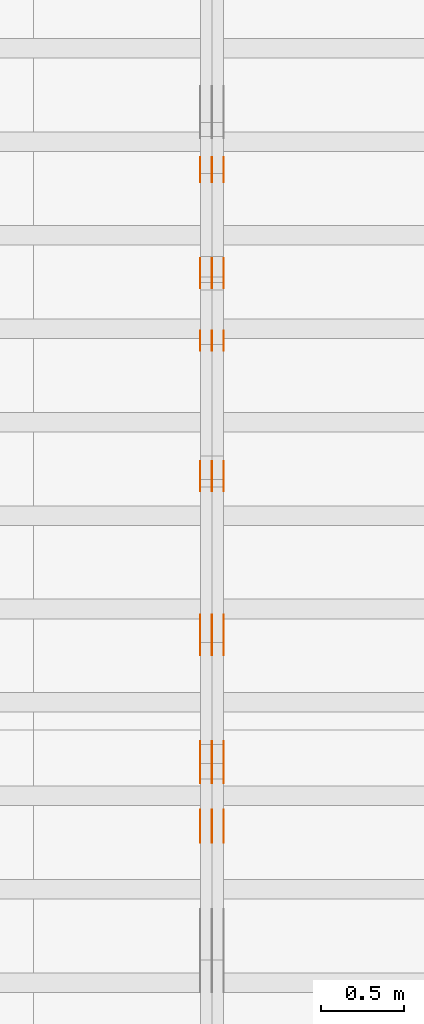
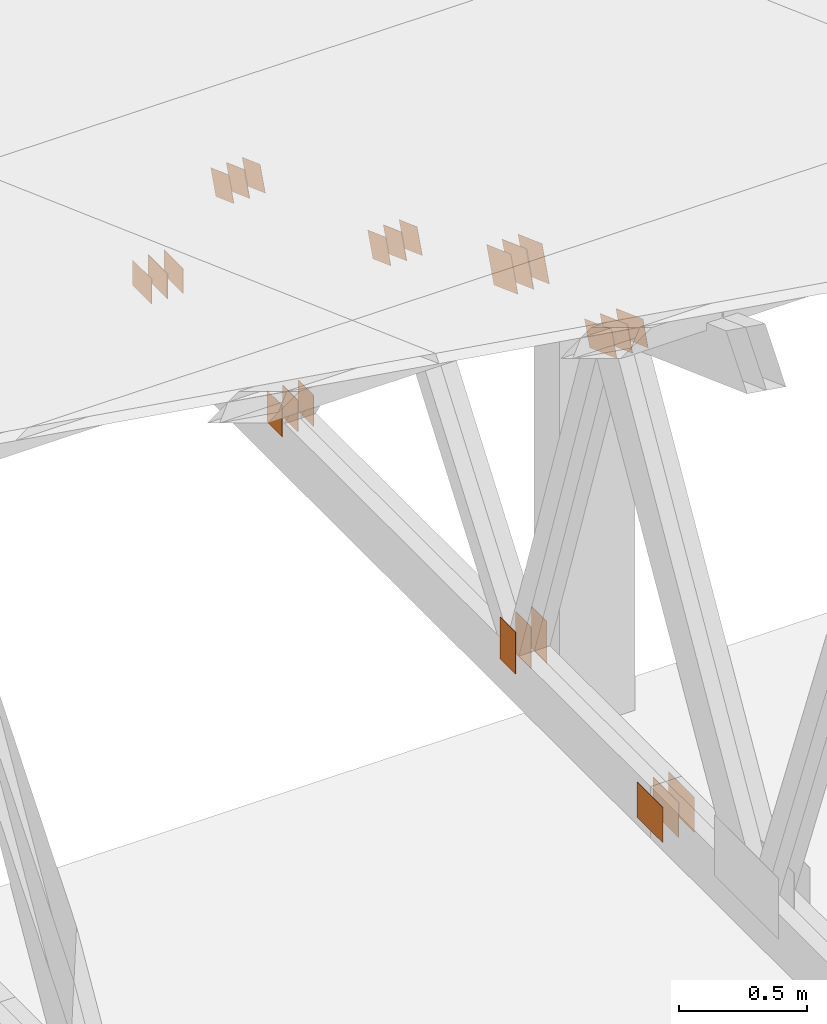
# One storey, part 128 of 189: 32 proxies.
"""IFC2X3 building model written with IfcOpenShell, lengths in millimetres."""

from ifc_helpers import new_model, entity, si_unit, converted_unit, derived_unit, direction, frame, frame_2d, origin, origin_2d_with_axis, place, context, subcontext, project, spatial, polyline, rectangle, outline, extrude, source, transform, mapped, material, type_object, type_shapes, element, save


model = new_model("IFC2X3")

# Units and contexts
model_context = context("Model", 3, precision=0.01, world=origin(), true_north=direction((6.12303176911189e-17, 1.0)))
body_context = subcontext(model_context, "Body", "Model", "MODEL_VIEW")
ifc_project = project(units=[si_unit("LENGTHUNIT", "METRE", prefix="MILLI"), si_unit("AREAUNIT", "SQUARE_METRE"), si_unit("VOLUMEUNIT", "CUBIC_METRE"), converted_unit("PLANEANGLEUNIT", "DEGREE", entity("IfcRatioMeasure", 0.0174532925199433), si_unit("PLANEANGLEUNIT", "RADIAN"), dimensions=[0, 0, 0, 0, 0, 0, 0]), si_unit("MASSUNIT", "GRAM", prefix="KILO"), derived_unit("MASSDENSITYUNIT", [(si_unit("MASSUNIT", "GRAM", prefix="KILO"), 1), (si_unit("LENGTHUNIT", "METRE"), -3)]), si_unit("TIMEUNIT", "SECOND"), si_unit("FREQUENCYUNIT", "HERTZ"), si_unit("THERMODYNAMICTEMPERATUREUNIT", "DEGREE_CELSIUS"), derived_unit("THERMALTRANSMITTANCEUNIT", [(si_unit("MASSUNIT", "GRAM", prefix="KILO"), 1), (si_unit("THERMODYNAMICTEMPERATUREUNIT", "KELVIN"), -1), (si_unit("TIMEUNIT", "SECOND"), -3)]), derived_unit("VOLUMETRICFLOWRATEUNIT", [(si_unit("LENGTHUNIT", "METRE"), 3), (si_unit("TIMEUNIT", "SECOND"), -1)]), si_unit("ELECTRICCURRENTUNIT", "AMPERE"), si_unit("ELECTRICVOLTAGEUNIT", "VOLT"), si_unit("POWERUNIT", "WATT"), si_unit("FORCEUNIT", "NEWTON"), si_unit("ILLUMINANCEUNIT", "LUX"), si_unit("LUMINOUSFLUXUNIT", "LUMEN"), si_unit("LUMINOUSINTENSITYUNIT", "CANDELA"), derived_unit("USERDEFINED", [(si_unit("MASSUNIT", "GRAM", prefix="KILO"), -1), (si_unit("LENGTHUNIT", "METRE"), -2), (si_unit("TIMEUNIT", "SECOND"), 3), (si_unit("LUMINOUSFLUXUNIT", "LUMEN"), 1)]), derived_unit("LINEARVELOCITYUNIT", [(si_unit("LENGTHUNIT", "METRE"), 1), (si_unit("TIMEUNIT", "SECOND"), -1)]), si_unit("PRESSUREUNIT", "PASCAL"), derived_unit("USERDEFINED", [(si_unit("LENGTHUNIT", "METRE"), -2), (si_unit("MASSUNIT", "GRAM", prefix="KILO"), 1), (si_unit("TIMEUNIT", "SECOND"), -2)])], contexts=[model_context])

# Site, building, storey
site_placement = place(None, origin())
site = spatial("IfcSite", under=ifc_project, at=site_placement, CompositionType="ELEMENT")
building_placement = place(site_placement, origin())
building = spatial("IfcBuilding", under=site, at=building_placement, CompositionType="ELEMENT")
storey_placement = place(building_placement, origin())
storey = spatial("IfcBuildingStorey", under=building, at=storey_placement, Name="Default", CompositionType="ELEMENT", Elevation=0.0)

# Proxies
ifc_material_1 = material(Name="IfcSurfaceStyle #122268")
building_element_proxy_type_1 = type_object("IfcBuildingElementProxyType", PredefinedType="NOTDEFINED", material=ifc_material_1)
shared_shape_1 = source(origin(), body_context, "Body", "SweptSolid", [
    extrude(outline(polyline([(-112.499846801582, -59.999986193028), (112.499924372729, -59.999986193028), (112.499888552087, 59.999986193028), (-112.499966123235, 59.999986193028), (-112.499846801582, -59.999986193028)])), frame((112.499989807712, 60.0001003787081, 0.0), z_axis=(0.0, 0.0, 1.0), x_axis=(-1.0, 0.0, 0.0)), (0.0, 0.0, 1.0), 1.3),
])
type_shapes(building_element_proxy_type_1, [shared_shape_1])
proxy_1_placement = place(building_placement, frame((21301.3, 24040.8868138992, 2049.61031693104), z_axis=(-1.0, 0.0, 0.0), x_axis=(0.0, -0.939692620785908, 0.342020143325669)))
element("IfcBuildingElementProxy", 1, at=proxy_1_placement, inside=storey, type_object=building_element_proxy_type_1, material=ifc_material_1, context=body_context, shape_type="MappedRepresentation", body=[
    mapped(shared_shape_1, transform((0.0, 0.0, 0.0), scale=1.0)),
])
ifc_material_2 = material(Name="IfcSurfaceStyle #122211")
building_element_proxy_type_2 = type_object("IfcBuildingElementProxyType", PredefinedType="NOTDEFINED", material=ifc_material_2)
shared_shape_2 = source(origin(), body_context, "Body", "SweptSolid", [
    extrude(outline(polyline([(-112.499846801582, -59.999986193028), (112.499924372729, -59.999986193028), (112.499888552087, 59.999986193028), (-112.499966123235, 59.999986193028), (-112.499846801582, -59.999986193028)])), frame((112.499989807712, 60.0001003787081, 0.0), z_axis=(0.0, 0.0, 1.0), x_axis=(-1.0, 0.0, 0.0)), (0.0, 0.0, 1.0), 1.29999999999998),
])
type_shapes(building_element_proxy_type_2, [shared_shape_2])
proxy_2_placement = place(building_placement, frame((21230.0, 24040.8868138992, 2049.61031693104), z_axis=(-1.0, 0.0, 0.0), x_axis=(0.0, -0.939692620785908, 0.342020143325669)))
element("IfcBuildingElementProxy", 2, at=proxy_2_placement, inside=storey, type_object=building_element_proxy_type_2, material=ifc_material_2, context=body_context, shape_type="MappedRepresentation", body=[
    mapped(shared_shape_2, transform((0.0, 0.0, 0.0), scale=1.0)),
])
ifc_material_3 = material(Name="IfcSurfaceStyle #122154")
building_element_proxy_type_3 = type_object("IfcBuildingElementProxyType", PredefinedType="NOTDEFINED", material=ifc_material_3)
shared_shape_3 = source(origin(), body_context, "Body", "SweptSolid", [
    extrude(outline(polyline([(-112.499846801582, -59.999986193028), (112.499924372729, -59.999986193028), (112.499888552087, 59.999986193028), (-112.499966123235, 59.999986193028), (-112.499846801582, -59.999986193028)])), frame((112.499989807712, 60.0001003787081, 0.0), z_axis=(0.0, 0.0, 1.0), x_axis=(-1.0, 0.0, 0.0)), (0.0, 0.0, 1.0), 1.29999999999998),
])
type_shapes(building_element_proxy_type_3, [shared_shape_3])
proxy_3_placement = place(building_placement, frame((21231.3, 24040.8868138992, 2049.61031693104), z_axis=(-1.0, 0.0, 0.0), x_axis=(0.0, -0.939692620785908, 0.342020143325669)))
element("IfcBuildingElementProxy", 3, at=proxy_3_placement, inside=storey, type_object=building_element_proxy_type_3, material=ifc_material_3, context=body_context, shape_type="MappedRepresentation", body=[
    mapped(shared_shape_3, transform((0.0, 0.0, 0.0), scale=1.0)),
])
ifc_material_4 = material(Name="IfcSurfaceStyle #122097")
building_element_proxy_type_4 = type_object("IfcBuildingElementProxyType", PredefinedType="NOTDEFINED", material=ifc_material_4)
shared_shape_4 = source(origin(), body_context, "Body", "SweptSolid", [
    extrude(outline(polyline([(-112.499846801582, -59.999986193028), (112.499924372729, -59.999986193028), (112.499888552087, 59.999986193028), (-112.499966123235, 59.999986193028), (-112.499846801582, -59.999986193028)])), frame((112.499989807712, 60.0001003787081, 0.0), z_axis=(0.0, 0.0, 1.0), x_axis=(-1.0, 0.0, 0.0)), (0.0, 0.0, 1.0), 1.29999999999999),
])
type_shapes(building_element_proxy_type_4, [shared_shape_4])
proxy_4_placement = place(building_placement, frame((21160.0, 24040.8868138992, 2049.61031693104), z_axis=(-1.0, 0.0, 0.0), x_axis=(0.0, -0.939692620785908, 0.342020143325669)))
element("IfcBuildingElementProxy", 4, at=proxy_4_placement, inside=storey, type_object=building_element_proxy_type_4, material=ifc_material_4, context=body_context, shape_type="MappedRepresentation", body=[
    mapped(shared_shape_4, transform((0.0, 0.0, 0.0), scale=1.0)),
])
ifc_material_5 = material(Name="IfcSurfaceStyle #122040")
building_element_proxy_type_5 = type_object("IfcBuildingElementProxyType", PredefinedType="NOTDEFINED", material=ifc_material_5)
shared_shape_5 = source(origin(), body_context, "Body", "SweptSolid", [
    extrude(rectangle(XDim=200.0, YDim=120.0, at=origin_2d_with_axis()), frame((100.0, 60.0002296775929, 0.0), z_axis=(0.0, 0.0, 1.0), x_axis=(-1.0, 0.0, 0.0)), (0.0, 0.0, 1.0), 1.3),
])
type_shapes(building_element_proxy_type_5, [shared_shape_5])
proxy_5_placement = place(building_placement, frame((21301.3, 24619.3435203224, 145.0), z_axis=(-1.0, 0.0, 0.0), x_axis=(0.0, 0.0, 1.0)))
element("IfcBuildingElementProxy", 5, at=proxy_5_placement, inside=storey, type_object=building_element_proxy_type_5, material=ifc_material_5, context=body_context, shape_type="MappedRepresentation", body=[
    mapped(shared_shape_5, transform((0.0, 0.0, 0.0), scale=1.0)),
])
ifc_material_6 = material(Name="IfcSurfaceStyle #121983")
building_element_proxy_type_6 = type_object("IfcBuildingElementProxyType", PredefinedType="NOTDEFINED", material=ifc_material_6)
shared_shape_6 = source(origin(), body_context, "Body", "SweptSolid", [
    extrude(rectangle(XDim=200.0, YDim=120.0, at=origin_2d_with_axis()), frame((100.0, 60.0002296775929, 0.0), z_axis=(0.0, 0.0, 1.0), x_axis=(-1.0, 0.0, 0.0)), (0.0, 0.0, 1.0), 1.29999999999998),
])
type_shapes(building_element_proxy_type_6, [shared_shape_6])
proxy_6_placement = place(building_placement, frame((21230.0, 24619.3435203224, 145.0), z_axis=(-1.0, 0.0, 0.0), x_axis=(0.0, 0.0, 1.0)))
element("IfcBuildingElementProxy", 6, at=proxy_6_placement, inside=storey, type_object=building_element_proxy_type_6, material=ifc_material_6, context=body_context, shape_type="MappedRepresentation", body=[
    mapped(shared_shape_6, transform((0.0, 0.0, 0.0), scale=1.0)),
])
ifc_material_7 = material(Name="IfcSurfaceStyle #121926")
building_element_proxy_type_7 = type_object("IfcBuildingElementProxyType", PredefinedType="NOTDEFINED", material=ifc_material_7)
shared_shape_7 = source(origin(), body_context, "Body", "SweptSolid", [
    extrude(rectangle(XDim=200.0, YDim=120.0, at=origin_2d_with_axis()), frame((100.0, 60.0002296775929, 0.0), z_axis=(0.0, 0.0, 1.0), x_axis=(-1.0, 0.0, 0.0)), (0.0, 0.0, 1.0), 1.29999999999998),
])
type_shapes(building_element_proxy_type_7, [shared_shape_7])
proxy_7_placement = place(building_placement, frame((21231.3, 24619.3435203224, 145.0), z_axis=(-1.0, 0.0, 0.0), x_axis=(0.0, 0.0, 1.0)))
element("IfcBuildingElementProxy", 7, at=proxy_7_placement, inside=storey, type_object=building_element_proxy_type_7, material=ifc_material_7, context=body_context, shape_type="MappedRepresentation", body=[
    mapped(shared_shape_7, transform((0.0, 0.0, 0.0), scale=1.0)),
])
ifc_material_8 = material(Name="IfcSurfaceStyle #121869")
building_element_proxy_type_8 = type_object("IfcBuildingElementProxyType", PredefinedType="NOTDEFINED", material=ifc_material_8)
shared_shape_8 = source(origin(), body_context, "Body", "SweptSolid", [
    extrude(rectangle(XDim=200.0, YDim=120.0, at=origin_2d_with_axis()), frame((100.0, 60.0002296775929, 0.0), z_axis=(0.0, 0.0, 1.0), x_axis=(-1.0, 0.0, 0.0)), (0.0, 0.0, 1.0), 1.29999999999999),
])
type_shapes(building_element_proxy_type_8, [shared_shape_8])
proxy_8_placement = place(building_placement, frame((21160.0, 24619.3435203224, 145.0), z_axis=(-1.0, 0.0, 0.0), x_axis=(0.0, 0.0, 1.0)))
element("IfcBuildingElementProxy", 8, at=proxy_8_placement, inside=storey, type_object=building_element_proxy_type_8, material=ifc_material_8, context=body_context, shape_type="MappedRepresentation", body=[
    mapped(shared_shape_8, transform((0.0, 0.0, 0.0), scale=1.0)),
])
ifc_material_9 = material(Name="IfcSurfaceStyle #121356")
building_element_proxy_type_9 = type_object("IfcBuildingElementProxyType", PredefinedType="NOTDEFINED", material=ifc_material_9)
shared_shape_9 = source(origin(), body_context, "Body", "SweptSolid", [
    extrude(outline(polyline([(-74.9999475298494, -60.0), (75.0000042257432, -60.0), (74.9999684051025, 60.0), (-75.0000251009963, 60.0), (-74.9999475298494, -60.0)])), frame((75.0000607644577, 60.0000865490217, 0.0), z_axis=(0.0, 0.0, 1.0), x_axis=(-1.0, 0.0, 0.0)), (0.0, 0.0, 1.0), 1.3),
])
type_shapes(building_element_proxy_type_9, [shared_shape_9])
proxy_9_placement = place(building_placement, frame((21301.3, 25732.0586805394, 1446.84420669249), z_axis=(-1.0, 0.0, 0.0), x_axis=(0.0, -0.939692620785908, 0.342020143325669)))
element("IfcBuildingElementProxy", 9, at=proxy_9_placement, inside=storey, type_object=building_element_proxy_type_9, material=ifc_material_9, context=body_context, shape_type="MappedRepresentation", body=[
    mapped(shared_shape_9, transform((0.0, 0.0, 0.0), scale=1.0)),
])
ifc_material_10 = material(Name="IfcSurfaceStyle #121299")
building_element_proxy_type_10 = type_object("IfcBuildingElementProxyType", PredefinedType="NOTDEFINED", material=ifc_material_10)
shared_shape_10 = source(origin(), body_context, "Body", "SweptSolid", [
    extrude(outline(polyline([(-74.9999475298494, -60.0), (75.0000042257432, -60.0), (74.9999684051025, 60.0), (-75.0000251009963, 60.0), (-74.9999475298494, -60.0)])), frame((75.0000607644577, 60.0000865490217, 0.0), z_axis=(0.0, 0.0, 1.0), x_axis=(-1.0, 0.0, 0.0)), (0.0, 0.0, 1.0), 1.29999999999999),
])
type_shapes(building_element_proxy_type_10, [shared_shape_10])
proxy_10_placement = place(building_placement, frame((21230.0, 25732.0586805394, 1446.84420669249), z_axis=(-1.0, 0.0, 0.0), x_axis=(0.0, -0.939692620785908, 0.342020143325669)))
element("IfcBuildingElementProxy", 10, at=proxy_10_placement, inside=storey, type_object=building_element_proxy_type_10, material=ifc_material_10, context=body_context, shape_type="MappedRepresentation", body=[
    mapped(shared_shape_10, transform((0.0, 0.0, 0.0), scale=1.0)),
])
ifc_material_11 = material(Name="IfcSurfaceStyle #121242")
building_element_proxy_type_11 = type_object("IfcBuildingElementProxyType", PredefinedType="NOTDEFINED", material=ifc_material_11)
shared_shape_11 = source(origin(), body_context, "Body", "SweptSolid", [
    extrude(outline(polyline([(-74.9999475298494, -60.0), (75.0000042257432, -60.0), (74.9999684051025, 60.0), (-75.0000251009963, 60.0), (-74.9999475298494, -60.0)])), frame((75.0000607644577, 60.0000865490217, 0.0), z_axis=(0.0, 0.0, 1.0), x_axis=(-1.0, 0.0, 0.0)), (0.0, 0.0, 1.0), 1.29999999999999),
])
type_shapes(building_element_proxy_type_11, [shared_shape_11])
proxy_11_placement = place(building_placement, frame((21231.3, 25732.0586805394, 1446.84420669249), z_axis=(-1.0, 0.0, 0.0), x_axis=(0.0, -0.939692620785908, 0.342020143325669)))
element("IfcBuildingElementProxy", 11, at=proxy_11_placement, inside=storey, type_object=building_element_proxy_type_11, material=ifc_material_11, context=body_context, shape_type="MappedRepresentation", body=[
    mapped(shared_shape_11, transform((0.0, 0.0, 0.0), scale=1.0)),
])
ifc_material_12 = material(Name="IfcSurfaceStyle #121185")
building_element_proxy_type_12 = type_object("IfcBuildingElementProxyType", PredefinedType="NOTDEFINED", material=ifc_material_12)
shared_shape_12 = source(origin(), body_context, "Body", "SweptSolid", [
    extrude(outline(polyline([(-74.9999475298494, -60.0), (75.0000042257432, -60.0), (74.9999684051025, 60.0), (-75.0000251009963, 60.0), (-74.9999475298494, -60.0)])), frame((75.0000607644577, 60.0000865490217, 0.0), z_axis=(0.0, 0.0, 1.0), x_axis=(-1.0, 0.0, 0.0)), (0.0, 0.0, 1.0), 1.29999999999999),
])
type_shapes(building_element_proxy_type_12, [shared_shape_12])
proxy_12_placement = place(building_placement, frame((21160.0, 25732.0586805394, 1446.84420669249), z_axis=(-1.0, 0.0, 0.0), x_axis=(0.0, -0.939692620785908, 0.342020143325669)))
element("IfcBuildingElementProxy", 12, at=proxy_12_placement, inside=storey, type_object=building_element_proxy_type_12, material=ifc_material_12, context=body_context, shape_type="MappedRepresentation", body=[
    mapped(shared_shape_12, transform((0.0, 0.0, 0.0), scale=1.0)),
])
ifc_material_13 = material(Name="IfcSurfaceStyle #121128")
building_element_proxy_type_13 = type_object("IfcBuildingElementProxyType", PredefinedType="NOTDEFINED", material=ifc_material_13)
shared_shape_13 = source(origin(), body_context, "Body", "SweptSolid", [
    extrude(rectangle(XDim=150.0, YDim=120.0, at=frame_2d((-7.105427357601e-15, 0.0), x_axis=(1.0, 0.0))), frame((75.0, 60.0, 0.0), z_axis=(0.0, 0.0, 1.0), x_axis=(-1.0, 0.0, 0.0)), (0.0, 0.0, 1.0), 1.3),
])
type_shapes(building_element_proxy_type_13, [shared_shape_13])
proxy_13_placement = place(building_placement, frame((21301.3, 26439.0083007813, 170.0), z_axis=(-1.0, 0.0, 0.0), x_axis=(0.0, 0.0, 1.0)))
element("IfcBuildingElementProxy", 13, at=proxy_13_placement, inside=storey, type_object=building_element_proxy_type_13, material=ifc_material_13, context=body_context, shape_type="MappedRepresentation", body=[
    mapped(shared_shape_13, transform((0.0, 0.0, 0.0), scale=1.0)),
])
ifc_material_14 = material(Name="IfcSurfaceStyle #121071")
building_element_proxy_type_14 = type_object("IfcBuildingElementProxyType", PredefinedType="NOTDEFINED", material=ifc_material_14)
shared_shape_14 = source(origin(), body_context, "Body", "SweptSolid", [
    extrude(rectangle(XDim=150.0, YDim=120.0, at=frame_2d((-7.105427357601e-15, 0.0), x_axis=(1.0, 0.0))), frame((75.0, 60.0, 0.0), z_axis=(0.0, 0.0, 1.0), x_axis=(-1.0, 0.0, 0.0)), (0.0, 0.0, 1.0), 1.29999999999999),
])
type_shapes(building_element_proxy_type_14, [shared_shape_14])
proxy_14_placement = place(building_placement, frame((21230.0, 26439.0083007813, 170.0), z_axis=(-1.0, 0.0, 0.0), x_axis=(0.0, 0.0, 1.0)))
element("IfcBuildingElementProxy", 14, at=proxy_14_placement, inside=storey, type_object=building_element_proxy_type_14, material=ifc_material_14, context=body_context, shape_type="MappedRepresentation", body=[
    mapped(shared_shape_14, transform((0.0, 0.0, 0.0), scale=1.0)),
])
ifc_material_15 = material(Name="IfcSurfaceStyle #121014")
building_element_proxy_type_15 = type_object("IfcBuildingElementProxyType", PredefinedType="NOTDEFINED", material=ifc_material_15)
shared_shape_15 = source(origin(), body_context, "Body", "SweptSolid", [
    extrude(rectangle(XDim=150.0, YDim=120.0, at=frame_2d((-7.105427357601e-15, 0.0), x_axis=(1.0, 0.0))), frame((75.0, 60.0, 0.0), z_axis=(0.0, 0.0, 1.0), x_axis=(-1.0, 0.0, 0.0)), (0.0, 0.0, 1.0), 1.29999999999999),
])
type_shapes(building_element_proxy_type_15, [shared_shape_15])
proxy_15_placement = place(building_placement, frame((21231.3, 26439.0083007813, 170.0), z_axis=(-1.0, 0.0, 0.0), x_axis=(0.0, 0.0, 1.0)))
element("IfcBuildingElementProxy", 15, at=proxy_15_placement, inside=storey, type_object=building_element_proxy_type_15, material=ifc_material_15, context=body_context, shape_type="MappedRepresentation", body=[
    mapped(shared_shape_15, transform((0.0, 0.0, 0.0), scale=1.0)),
])
ifc_material_16 = material(Name="IfcSurfaceStyle #120957")
building_element_proxy_type_16 = type_object("IfcBuildingElementProxyType", PredefinedType="NOTDEFINED", material=ifc_material_16)
shared_shape_16 = source(origin(), body_context, "Body", "SweptSolid", [
    extrude(rectangle(XDim=150.0, YDim=120.0, at=frame_2d((-7.105427357601e-15, 0.0), x_axis=(1.0, 0.0))), frame((75.0, 60.0, 0.0), z_axis=(0.0, 0.0, 1.0), x_axis=(-1.0, 0.0, 0.0)), (0.0, 0.0, 1.0), 1.29999999999999),
])
type_shapes(building_element_proxy_type_16, [shared_shape_16])
proxy_16_placement = place(building_placement, frame((21160.0, 26439.0083007813, 170.0), z_axis=(-1.0, 0.0, 0.0), x_axis=(0.0, 0.0, 1.0)))
element("IfcBuildingElementProxy", 16, at=proxy_16_placement, inside=storey, type_object=building_element_proxy_type_16, material=ifc_material_16, context=body_context, shape_type="MappedRepresentation", body=[
    mapped(shared_shape_16, transform((0.0, 0.0, 0.0), scale=1.0)),
])
ifc_material_17 = material(Name="IfcSurfaceStyle #120444")
building_element_proxy_type_17 = type_object("IfcBuildingElementProxyType", PredefinedType="NOTDEFINED", material=ifc_material_17)
shared_shape_17 = source(origin(), body_context, "Body", "SweptSolid", [
    extrude(outline(polyline([(-74.9999684051023, -60.0), (75.0000251009964, -60.0), (74.9999475298495, 60.0), (-75.0000042257435, 60.0), (-74.9999684051023, -60.0)])), frame((75.0000251009964, 60.0000006265238, 0.0), z_axis=(0.0, 0.0, 1.0), x_axis=(-1.0, 0.0, 0.0)), (0.0, 0.0, 1.0), 1.3),
])
type_shapes(building_element_proxy_type_17, [shared_shape_17])
proxy_17_placement = place(building_placement, frame((21301.3, 26956.490053282, 1001.18769055967), z_axis=(-1.0, 0.0, 0.0), x_axis=(0.0, -0.939692620785908, 0.342020143325669)))
element("IfcBuildingElementProxy", 17, at=proxy_17_placement, inside=storey, type_object=building_element_proxy_type_17, material=ifc_material_17, context=body_context, shape_type="MappedRepresentation", body=[
    mapped(shared_shape_17, transform((0.0, 0.0, 0.0), scale=1.0)),
])
ifc_material_18 = material(Name="IfcSurfaceStyle #120387")
building_element_proxy_type_18 = type_object("IfcBuildingElementProxyType", PredefinedType="NOTDEFINED", material=ifc_material_18)
shared_shape_18 = source(origin(), body_context, "Body", "SweptSolid", [
    extrude(outline(polyline([(-74.9999684051023, -60.0), (75.0000251009964, -60.0), (74.9999475298495, 60.0), (-75.0000042257435, 60.0), (-74.9999684051023, -60.0)])), frame((75.0000251009964, 60.0000006265238, 0.0), z_axis=(0.0, 0.0, 1.0), x_axis=(-1.0, 0.0, 0.0)), (0.0, 0.0, 1.0), 1.29999999999999),
])
type_shapes(building_element_proxy_type_18, [shared_shape_18])
proxy_18_placement = place(building_placement, frame((21230.0, 26956.490053282, 1001.18769055967), z_axis=(-1.0, 0.0, 0.0), x_axis=(0.0, -0.939692620785908, 0.342020143325669)))
element("IfcBuildingElementProxy", 18, at=proxy_18_placement, inside=storey, type_object=building_element_proxy_type_18, material=ifc_material_18, context=body_context, shape_type="MappedRepresentation", body=[
    mapped(shared_shape_18, transform((0.0, 0.0, 0.0), scale=1.0)),
])
ifc_material_19 = material(Name="IfcSurfaceStyle #120330")
building_element_proxy_type_19 = type_object("IfcBuildingElementProxyType", PredefinedType="NOTDEFINED", material=ifc_material_19)
shared_shape_19 = source(origin(), body_context, "Body", "SweptSolid", [
    extrude(outline(polyline([(-74.9999684051023, -60.0), (75.0000251009964, -60.0), (74.9999475298495, 60.0), (-75.0000042257435, 60.0), (-74.9999684051023, -60.0)])), frame((75.0000251009964, 60.0000006265238, 0.0), z_axis=(0.0, 0.0, 1.0), x_axis=(-1.0, 0.0, 0.0)), (0.0, 0.0, 1.0), 1.29999999999999),
])
type_shapes(building_element_proxy_type_19, [shared_shape_19])
proxy_19_placement = place(building_placement, frame((21231.3, 26956.490053282, 1001.18769055967), z_axis=(-1.0, 0.0, 0.0), x_axis=(0.0, -0.939692620785908, 0.342020143325669)))
element("IfcBuildingElementProxy", 19, at=proxy_19_placement, inside=storey, type_object=building_element_proxy_type_19, material=ifc_material_19, context=body_context, shape_type="MappedRepresentation", body=[
    mapped(shared_shape_19, transform((0.0, 0.0, 0.0), scale=1.0)),
])
ifc_material_20 = material(Name="IfcSurfaceStyle #120273")
building_element_proxy_type_20 = type_object("IfcBuildingElementProxyType", PredefinedType="NOTDEFINED", material=ifc_material_20)
shared_shape_20 = source(origin(), body_context, "Body", "SweptSolid", [
    extrude(outline(polyline([(-74.9999684051023, -60.0), (75.0000251009964, -60.0), (74.9999475298495, 60.0), (-75.0000042257435, 60.0), (-74.9999684051023, -60.0)])), frame((75.0000251009964, 60.0000006265238, 0.0), z_axis=(0.0, 0.0, 1.0), x_axis=(-1.0, 0.0, 0.0)), (0.0, 0.0, 1.0), 1.29999999999999),
])
type_shapes(building_element_proxy_type_20, [shared_shape_20])
proxy_20_placement = place(building_placement, frame((21160.0, 26956.490053282, 1001.18769055967), z_axis=(-1.0, 0.0, 0.0), x_axis=(0.0, -0.939692620785908, 0.342020143325669)))
element("IfcBuildingElementProxy", 20, at=proxy_20_placement, inside=storey, type_object=building_element_proxy_type_20, material=ifc_material_20, context=body_context, shape_type="MappedRepresentation", body=[
    mapped(shared_shape_20, transform((0.0, 0.0, 0.0), scale=1.0)),
])
ifc_material_21 = material(Name="IfcSurfaceStyle #120216")
building_element_proxy_type_21 = type_object("IfcBuildingElementProxyType", PredefinedType="NOTDEFINED", material=ifc_material_21)
shared_shape_21 = source(origin(), body_context, "Body", "SweptSolid", [
    extrude(rectangle(XDim=150.0, YDim=120.0, at=origin_2d_with_axis()), frame((75.0, 60.0, 0.0), z_axis=(0.0, 0.0, 1.0), x_axis=(-1.0, 0.0, 0.0)), (0.0, 0.0, 1.0), 1.3),
])
type_shapes(building_element_proxy_type_21, [shared_shape_21])
proxy_21_placement = place(building_placement, frame((21301.3, 27607.3129882813, 185.0), z_axis=(-1.0, 0.0, 0.0), x_axis=(0.0, -1.0, 0.0)))
element("IfcBuildingElementProxy", 21, at=proxy_21_placement, inside=storey, type_object=building_element_proxy_type_21, material=ifc_material_21, context=body_context, shape_type="MappedRepresentation", body=[
    mapped(shared_shape_21, transform((0.0, 0.0, 0.0), scale=1.0)),
])
ifc_material_22 = material(Name="IfcSurfaceStyle #120159")
building_element_proxy_type_22 = type_object("IfcBuildingElementProxyType", PredefinedType="NOTDEFINED", material=ifc_material_22)
shared_shape_22 = source(origin(), body_context, "Body", "SweptSolid", [
    extrude(rectangle(XDim=150.0, YDim=120.0, at=origin_2d_with_axis()), frame((75.0, 60.0, 0.0), z_axis=(0.0, 0.0, 1.0), x_axis=(-1.0, 0.0, 0.0)), (0.0, 0.0, 1.0), 1.29999999999999),
])
type_shapes(building_element_proxy_type_22, [shared_shape_22])
proxy_22_placement = place(building_placement, frame((21230.0, 27607.3129882813, 185.0), z_axis=(-1.0, 0.0, 0.0), x_axis=(0.0, -1.0, 0.0)))
element("IfcBuildingElementProxy", 22, at=proxy_22_placement, inside=storey, type_object=building_element_proxy_type_22, material=ifc_material_22, context=body_context, shape_type="MappedRepresentation", body=[
    mapped(shared_shape_22, transform((0.0, 0.0, 0.0), scale=1.0)),
])
ifc_material_23 = material(Name="IfcSurfaceStyle #120102")
building_element_proxy_type_23 = type_object("IfcBuildingElementProxyType", PredefinedType="NOTDEFINED", material=ifc_material_23)
shared_shape_23 = source(origin(), body_context, "Body", "SweptSolid", [
    extrude(rectangle(XDim=150.0, YDim=120.0, at=origin_2d_with_axis()), frame((75.0, 60.0, 0.0), z_axis=(0.0, 0.0, 1.0), x_axis=(-1.0, 0.0, 0.0)), (0.0, 0.0, 1.0), 1.29999999999999),
])
type_shapes(building_element_proxy_type_23, [shared_shape_23])
proxy_23_placement = place(building_placement, frame((21231.3, 27607.3129882813, 185.0), z_axis=(-1.0, 0.0, 0.0), x_axis=(0.0, -1.0, 0.0)))
element("IfcBuildingElementProxy", 23, at=proxy_23_placement, inside=storey, type_object=building_element_proxy_type_23, material=ifc_material_23, context=body_context, shape_type="MappedRepresentation", body=[
    mapped(shared_shape_23, transform((0.0, 0.0, 0.0), scale=1.0)),
])
ifc_material_24 = material(Name="IfcSurfaceStyle #120045")
building_element_proxy_type_24 = type_object("IfcBuildingElementProxyType", PredefinedType="NOTDEFINED", material=ifc_material_24)
shared_shape_24 = source(origin(), body_context, "Body", "SweptSolid", [
    extrude(rectangle(XDim=150.0, YDim=120.0, at=origin_2d_with_axis()), frame((75.0, 60.0, 0.0), z_axis=(0.0, 0.0, 1.0), x_axis=(-1.0, 0.0, 0.0)), (0.0, 0.0, 1.0), 1.29999999999999),
])
type_shapes(building_element_proxy_type_24, [shared_shape_24])
proxy_24_placement = place(building_placement, frame((21160.0, 27607.3129882813, 185.0), z_axis=(-1.0, 0.0, 0.0), x_axis=(0.0, -1.0, 0.0)))
element("IfcBuildingElementProxy", 24, at=proxy_24_placement, inside=storey, type_object=building_element_proxy_type_24, material=ifc_material_24, context=body_context, shape_type="MappedRepresentation", body=[
    mapped(shared_shape_24, transform((0.0, 0.0, 0.0), scale=1.0)),
])
ifc_material_25 = material(Name="IfcSurfaceStyle #118392")
building_element_proxy_type_25 = type_object("IfcBuildingElementProxyType", PredefinedType="NOTDEFINED", material=ifc_material_25)
shared_shape_25 = source(origin(), body_context, "Body", "SweptSolid", [
    extrude(rectangle(XDim=200.0, YDim=168.0, at=origin_2d_with_axis()), frame((100.0, 84.0, 0.0), z_axis=(0.0, 0.0, 1.0), x_axis=(-1.0, 0.0, 0.0)), (0.0, 0.0, 1.0), 1.3),
])
type_shapes(building_element_proxy_type_25, [shared_shape_25])
proxy_25_placement = place(building_placement, frame((21301.3, 23470.0, 206.5), z_axis=(-1.0, 0.0, 0.0), x_axis=(0.0, 1.0, 0.0)))
element("IfcBuildingElementProxy", 25, at=proxy_25_placement, inside=storey, type_object=building_element_proxy_type_25, material=ifc_material_25, context=body_context, shape_type="MappedRepresentation", body=[
    mapped(shared_shape_25, transform((0.0, 0.0, 0.0), scale=1.0)),
])
ifc_material_26 = material(Name="IfcSurfaceStyle #118335")
building_element_proxy_type_26 = type_object("IfcBuildingElementProxyType", PredefinedType="NOTDEFINED", material=ifc_material_26)
shared_shape_26 = source(origin(), body_context, "Body", "SweptSolid", [
    extrude(rectangle(XDim=200.0, YDim=168.0, at=origin_2d_with_axis()), frame((100.0, 84.0, 0.0), z_axis=(0.0, 0.0, 1.0), x_axis=(-1.0, 0.0, 0.0)), (0.0, 0.0, 1.0), 1.29999999999998),
])
type_shapes(building_element_proxy_type_26, [shared_shape_26])
proxy_26_placement = place(building_placement, frame((21230.0, 23470.0, 206.5), z_axis=(-1.0, 0.0, 0.0), x_axis=(0.0, 1.0, 0.0)))
element("IfcBuildingElementProxy", 26, at=proxy_26_placement, inside=storey, type_object=building_element_proxy_type_26, material=ifc_material_26, context=body_context, shape_type="MappedRepresentation", body=[
    mapped(shared_shape_26, transform((0.0, 0.0, 0.0), scale=1.0)),
])
ifc_material_27 = material(Name="IfcSurfaceStyle #118278")
building_element_proxy_type_27 = type_object("IfcBuildingElementProxyType", PredefinedType="NOTDEFINED", material=ifc_material_27)
shared_shape_27 = source(origin(), body_context, "Body", "SweptSolid", [
    extrude(rectangle(XDim=200.0, YDim=168.0, at=origin_2d_with_axis()), frame((100.0, 84.0, 0.0), z_axis=(0.0, 0.0, 1.0), x_axis=(-1.0, 0.0, 0.0)), (0.0, 0.0, 1.0), 1.29999999999998),
])
type_shapes(building_element_proxy_type_27, [shared_shape_27])
proxy_27_placement = place(building_placement, frame((21231.3, 23470.0, 206.5), z_axis=(-1.0, 0.0, 0.0), x_axis=(0.0, 1.0, 0.0)))
element("IfcBuildingElementProxy", 27, at=proxy_27_placement, inside=storey, type_object=building_element_proxy_type_27, material=ifc_material_27, context=body_context, shape_type="MappedRepresentation", body=[
    mapped(shared_shape_27, transform((0.0, 0.0, 0.0), scale=1.0)),
])
ifc_material_28 = material(Name="IfcSurfaceStyle #118221")
building_element_proxy_type_28 = type_object("IfcBuildingElementProxyType", PredefinedType="NOTDEFINED", material=ifc_material_28)
shared_shape_28 = source(origin(), body_context, "Body", "SweptSolid", [
    extrude(rectangle(XDim=200.0, YDim=168.0, at=origin_2d_with_axis()), frame((100.0, 84.0, 0.0), z_axis=(0.0, 0.0, 1.0), x_axis=(-1.0, 0.0, 0.0)), (0.0, 0.0, 1.0), 1.29999999999999),
])
type_shapes(building_element_proxy_type_28, [shared_shape_28])
proxy_28_placement = place(building_placement, frame((21160.0, 23470.0, 206.5), z_axis=(-1.0, 0.0, 0.0), x_axis=(0.0, 1.0, 0.0)))
element("IfcBuildingElementProxy", 28, at=proxy_28_placement, inside=storey, type_object=building_element_proxy_type_28, material=ifc_material_28, context=body_context, shape_type="MappedRepresentation", body=[
    mapped(shared_shape_28, transform((0.0, 0.0, 0.0), scale=1.0)),
])
ifc_material_29 = material(Name="IfcSurfaceStyle #116232")
building_element_proxy_type_29 = type_object("IfcBuildingElementProxyType", PredefinedType="NOTDEFINED", material=ifc_material_29)
shared_shape_29 = source(origin(), body_context, "Body", "SweptSolid", [
    extrude(outline(polyline([(-99.9999065788418, -84.0000755647729), (99.9999734279406, -84.0000755647729), (99.9999483293475, 84.000075564773), (-100.000015178446, 84.000075564773), (-99.9999065788418, -84.0000755647729)])), frame((100.000157783747, 84.0001144608011, 0.0), z_axis=(0.0, 0.0, 1.0), x_axis=(-1.0, 0.0, 0.0)), (0.0, 0.0, 1.0), 1.3),
])
type_shapes(building_element_proxy_type_29, [shared_shape_29])
proxy_29_placement = place(building_placement, frame((21301.3, 24788.4767593228, 1895.10136879206), z_axis=(-1.0, 0.0, 0.0), x_axis=(0.0, -0.939692620785908, 0.342020143325669)))
element("IfcBuildingElementProxy", 29, at=proxy_29_placement, inside=storey, type_object=building_element_proxy_type_29, material=ifc_material_29, context=body_context, shape_type="MappedRepresentation", body=[
    mapped(shared_shape_29, transform((0.0, 0.0, 0.0), scale=1.0)),
])
ifc_material_30 = material(Name="IfcSurfaceStyle #116175")
building_element_proxy_type_30 = type_object("IfcBuildingElementProxyType", PredefinedType="NOTDEFINED", material=ifc_material_30)
shared_shape_30 = source(origin(), body_context, "Body", "SweptSolid", [
    extrude(outline(polyline([(-99.9999065788418, -84.0000755647729), (99.9999734279406, -84.0000755647729), (99.9999483293475, 84.000075564773), (-100.000015178446, 84.000075564773), (-99.9999065788418, -84.0000755647729)])), frame((100.000157783747, 84.0001144608011, 0.0), z_axis=(0.0, 0.0, 1.0), x_axis=(-1.0, 0.0, 0.0)), (0.0, 0.0, 1.0), 1.29999999999998),
])
type_shapes(building_element_proxy_type_30, [shared_shape_30])
proxy_30_placement = place(building_placement, frame((21230.0, 24788.4767593228, 1895.10136879206), z_axis=(-1.0, 0.0, 0.0), x_axis=(0.0, -0.939692620785908, 0.342020143325669)))
element("IfcBuildingElementProxy", 30, at=proxy_30_placement, inside=storey, type_object=building_element_proxy_type_30, material=ifc_material_30, context=body_context, shape_type="MappedRepresentation", body=[
    mapped(shared_shape_30, transform((0.0, 0.0, 0.0), scale=1.0)),
])
ifc_material_31 = material(Name="IfcSurfaceStyle #116118")
building_element_proxy_type_31 = type_object("IfcBuildingElementProxyType", PredefinedType="NOTDEFINED", material=ifc_material_31)
shared_shape_31 = source(origin(), body_context, "Body", "SweptSolid", [
    extrude(outline(polyline([(-99.9999065788418, -84.0000755647729), (99.9999734279406, -84.0000755647729), (99.9999483293475, 84.000075564773), (-100.000015178446, 84.000075564773), (-99.9999065788418, -84.0000755647729)])), frame((100.000157783747, 84.0001144608011, 0.0), z_axis=(0.0, 0.0, 1.0), x_axis=(-1.0, 0.0, 0.0)), (0.0, 0.0, 1.0), 1.29999999999998),
])
type_shapes(building_element_proxy_type_31, [shared_shape_31])
proxy_31_placement = place(building_placement, frame((21231.3, 24788.4767593228, 1895.10136879206), z_axis=(-1.0, 0.0, 0.0), x_axis=(0.0, -0.939692620785908, 0.342020143325669)))
element("IfcBuildingElementProxy", 31, at=proxy_31_placement, inside=storey, type_object=building_element_proxy_type_31, material=ifc_material_31, context=body_context, shape_type="MappedRepresentation", body=[
    mapped(shared_shape_31, transform((0.0, 0.0, 0.0), scale=1.0)),
])
ifc_material_32 = material(Name="IfcSurfaceStyle #116061")
building_element_proxy_type_32 = type_object("IfcBuildingElementProxyType", PredefinedType="NOTDEFINED", material=ifc_material_32)
shared_shape_32 = source(origin(), body_context, "Body", "SweptSolid", [
    extrude(outline(polyline([(-99.9999065788418, -84.0000755647729), (99.9999734279406, -84.0000755647729), (99.9999483293475, 84.000075564773), (-100.000015178446, 84.000075564773), (-99.9999065788418, -84.0000755647729)])), frame((100.000157783747, 84.0001144608011, 0.0), z_axis=(0.0, 0.0, 1.0), x_axis=(-1.0, 0.0, 0.0)), (0.0, 0.0, 1.0), 1.29999999999999),
])
type_shapes(building_element_proxy_type_32, [shared_shape_32])
proxy_32_placement = place(building_placement, frame((21160.0, 24788.4767593228, 1895.10136879206), z_axis=(-1.0, 0.0, 0.0), x_axis=(0.0, -0.939692620785908, 0.342020143325669)))
element("IfcBuildingElementProxy", 32, at=proxy_32_placement, inside=storey, type_object=building_element_proxy_type_32, material=ifc_material_32, context=body_context, shape_type="MappedRepresentation", body=[
    mapped(shared_shape_32, transform((0.0, 0.0, 0.0), scale=1.0)),
])

save(model, "model.ifc")
